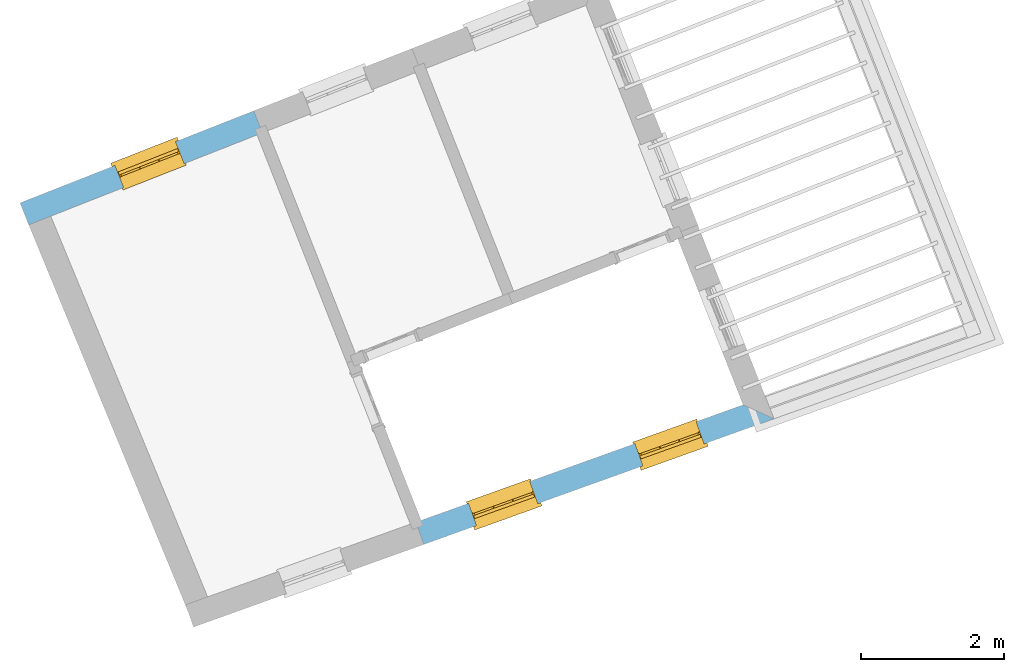
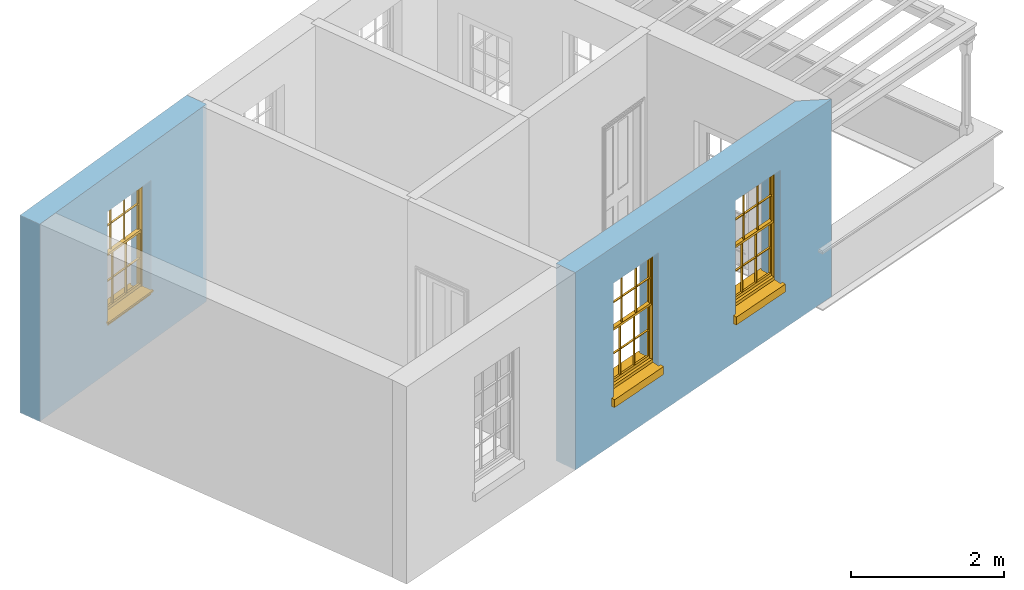
# One storey, part 3 of 8: 3 windows, 3 openings, plus 2 elements that do not belong to this part.
"""IFC2X3 building model written with IfcOpenShell, lengths in metres."""

from ifc_helpers import new_model, si_unit, frame, origin, place, context, subcontext, project, spatial, polyline, outline, extrude, faceted_brep, material, layer, layer_set, layer_usage, element, fill, save


model = new_model("IFC2X3")

# Units and contexts
model_context = context("Model", 3, world=origin())
body_context = subcontext(model_context, "Body", "Model", "MODEL_VIEW")
ifc_project = project(units=[si_unit("PLANEANGLEUNIT", "RADIAN"), si_unit("MASSUNIT", "GRAM", prefix="KILO"), si_unit("FORCEUNIT", "NEWTON", prefix="KILO"), si_unit("LENGTHUNIT", "METRE")], contexts=[model_context])

# Site, building, storey
site_placement = place(None, origin())
site = spatial("IfcSite", under=ifc_project, at=site_placement, CompositionType="ELEMENT")
building_placement = place(None, origin())
building = spatial("IfcBuilding", under=site, at=building_placement, Name="Building plot-4", CompositionType="ELEMENT")
storey_placement = place(None, frame((0.0, 0.0, 9.45)))
storey = spatial("IfcBuildingStorey", under=building, at=storey_placement, Name="Floor 2", CompositionType="ELEMENT", Elevation=9.45)

# Wall, openings, windows
ifc_material = material(Name="Masonry")
ifc_layer = layer(ifc_material, 0.33, ventilated=False)
ifc_layer_set = layer_set([ifc_layer], Name="My Wall")
ifc_layer_usage = layer_usage(ifc_layer_set, "AXIS2", "NEGATIVE", 0.08)
wall_1_placement = place(storey_placement, origin())
wall_1 = element("IfcWallStandardCase", 1, at=wall_1_placement, inside=storey, material=ifc_layer_usage, Name="exterior", context=body_context, shape_type="SweptSolid", body=[
    extrude(outline(polyline([(49.5927970052436, 46.539607653732), (49.70423854185, 46.2289940933087), (54.5866021542831, 47.9806822762042), (54.1548638616126, 48.176380175453), (49.5927970052436, 46.539607653732)])), origin(), (0.0, 0.0, 1.0), 3.15),
])
opening_1_placement = place(storey_placement, frame((0.0, 0.0, 0.75)))
opening_1 = element("IfcOpeningElement", 2, at=opening_1_placement, cuts=wall_1, Name="Opening", ObjectType="Opening", context=body_context, shape_type="SweptSolid", body=[
    extrude(outline(polyline([(50.4358969684534, 46.4914975693984), (51.2924373926509, 46.7988060491311), (51.1809958560445, 47.1094196095543), (50.3244554318471, 46.8021111298216), (50.4358969684534, 46.4914975693984)])), origin(), (0.0, 0.0, 1.0), 1.82),
])
opening_2_placement = place(storey_placement, frame((0.0, 0.0, 0.75)))
opening_2 = element("IfcOpeningElement", 3, at=opening_2_placement, cuts=wall_1, Name="Opening", ObjectType="Opening", context=body_context, shape_type="SweptSolid", body=[
    extrude(outline(polyline([(52.7557542458578, 47.3238130013103), (53.6122946700553, 47.631121481043), (53.5008531334489, 47.9417350414663), (52.6443127092515, 47.6344265617336), (52.7557542458578, 47.3238130013103)])), origin(), (0.0, 0.0, 1.0), 1.82),
])
window_1_placement = place(storey_placement, frame((50.3514715619335, 46.7268108727493, 0.75), z_axis=(0.0, 0.0, 1.0), x_axis=(0.856540424197469, 0.307308479732683, 0.0)))
window_1 = element("IfcWindow", 4, at=window_1_placement, inside=storey, Name="circulation outside window", OverallHeight=1.82, OverallWidth=0.91, context=body_context, shape_type="Brep", held_by="IfcProductRepresentation", body=[
    faceted_brep([(0.033125, -0.105, 0.975209), (0.01, -0.105, 0.975209), (0.033125, -0.105, 1.376042), (0.876875, -0.105, 0.975209), (0.876875, -0.105, 1.376042), (0.9, -0.105, 0.975209), (0.876875, -0.105, 1.386042), (0.876875, -0.105, 1.786875), (0.9, -0.105, 1.81), (0.033125, -0.105, 1.786875), (0.033125, -0.105, 1.386042), (0.01, -0.105, 1.81), (0.876875, -0.135, 1.376042), (0.876875, -0.135, 0.975209), (0.9, -0.135, 0.937083), (0.033125, -0.135, 1.786875), (0.01, -0.135, 1.81), (0.033125, -0.135, 1.386042), (0.01, -0.135, 0.937083), (0.033125, -0.135, 0.975209), (0.033125, -0.135, 1.376042), (0.876875, -0.135, 1.786875), (0.876875, -0.135, 1.386042), (0.9, -0.135, 1.81), (0.033125, -0.105, 0.937083), (0.01, -0.105, 0.937083), (0.033125, -0.105, 0.53625), (0.876875, -0.105, 0.937083), (0.876875, -0.105, 0.53625), (0.9, -0.105, 0.937083), (0.876875, -0.105, 0.52625), (0.876875, -0.105, 0.125417), (0.9, -0.105, 0.077167), (0.033125, -0.105, 0.125417), (0.033125, -0.105, 0.52625), (0.01, -0.105, 0.077167), (-0.0425, -0.25, 0.01), (-0.0425, -0.3, 0.001667), (0.0, -0.25, 0.01), (0.9525, -0.25, 0.01), (0.91, -0.25, 0.01), (0.9525, -0.3, 0.001667), (-0.02, 0.08, 0.077167), (0.0, 0.08, 0.077167), (-0.02, 0.11, 0.077167), (0.0, -0.06, 0.077167), (0.01, -0.06, 0.077167), (0.91, -0.06, 0.077167), (0.91, 0.08, 0.077167), (0.9, -0.06, 0.077167), (0.93, 0.08, 0.077167), (0.93, 0.11, 0.077167), (0.01, -0.075, 0.975209), (0.9, -0.075, 0.975209), (0.876875, -0.075, 0.125417), (0.876875, -0.075, 0.52625), (0.9, -0.075, 0.077167), (0.876875, -0.075, 0.53625), (0.876875, -0.075, 0.937083), (0.033125, -0.075, 0.125417), (0.01, -0.075, 0.077167), (0.033125, -0.075, 0.52625), (0.033125, -0.075, 0.937083), (0.033125, -0.075, 0.53625), (-0.02, 0.08, 0.052167), (-0.02, 0.11, 0.052167), (0.93, 0.11, 0.052167), (0.93, 0.08, 0.052167), (0.91, 0.08, 0.052167), (0.0, 0.08, 0.052167), (0.91, -0.15, 0.026667), (0.0, -0.15, 0.026667), (-0.0425, -0.3, -0.123333), (0.9525, -0.3, -0.123333), (-0.0425, -0.25, -0.123333), (0.9525, -0.25, -0.123333), (0.01, -0.06, 1.81), (0.9, -0.06, 1.81), (0.0, -0.06, 1.82), (0.91, -0.06, 1.82), (0.01, -0.15, 0.077167), (0.9, -0.15, 0.077167), (0.592292, -0.105, 0.125417), (0.592292, -0.075, 0.125417), (0.317708, -0.075, 0.125417), (0.317708, -0.105, 0.125417), (0.592292, -0.105, 0.53625), (0.317708, -0.105, 0.53625), (0.317708, -0.105, 0.52625), (0.592292, -0.105, 0.52625), (0.592292, -0.075, 0.53625), (0.317708, -0.075, 0.53625), (0.592292, -0.135, 1.386042), (0.592292, -0.105, 1.386042), (0.317708, -0.105, 1.386042), (0.317708, -0.135, 1.386042), (0.317708, -0.135, 1.376042), (0.592292, -0.135, 1.376042), (0.317708, -0.105, 1.376042), (0.592292, -0.105, 1.376042), (0.602292, -0.135, 1.376042), (0.592292, -0.135, 0.975209), (0.602292, -0.135, 0.975209), (0.602292, -0.105, 0.975209), (0.592292, -0.105, 0.975209), (0.602292, -0.105, 1.376042), (0.602292, -0.075, 0.53625), (0.602292, -0.105, 0.53625), (0.317708, -0.075, 0.52625), (0.307708, -0.075, 0.125417), (0.307708, -0.075, 0.52625), (0.602292, -0.075, 0.52625), (0.602292, -0.075, 0.125417), (0.592292, -0.075, 0.52625), (0.307708, -0.075, 0.53625), (0.317708, -0.075, 0.937083), (0.307708, -0.075, 0.937083), (0.602292, -0.075, 0.937083), (0.592292, -0.075, 0.937083), (0.307708, -0.105, 0.52625), (0.307708, -0.105, 0.125417), (0.307708, -0.105, 0.53625), (0.307708, -0.105, 0.937083), (0.592292, -0.105, 0.937083), (0.317708, -0.105, 0.937083), (0.602292, -0.105, 0.937083), (0.602292, -0.105, 0.52625), (0.602292, -0.105, 0.125417), (0.307708, -0.135, 1.386042), (0.307708, -0.135, 1.376042), (0.307708, -0.135, 0.975209), (0.317708, -0.135, 0.975209), (0.317708, -0.135, 1.786875), (0.307708, -0.135, 1.786875), (0.602292, -0.135, 1.786875), (0.592292, -0.135, 1.786875), (0.602292, -0.135, 1.386042), (0.602292, -0.105, 1.386042), (0.307708, -0.105, 1.386042), (0.307708, -0.105, 1.786875), (0.317708, -0.105, 1.786875), (0.592292, -0.105, 1.786875), (0.602292, -0.105, 1.786875), (0.307708, -0.105, 1.376042), (0.317708, -0.105, 0.975209), (0.307708, -0.105, 0.975209), (0.91, -0.15, 1.82), (0.9, -0.15, 1.81), (0.01, -0.15, 1.81), (0.0, -0.15, 1.82), (0.91, -0.25, 0.0), (0.0, -0.25, 0.0), (0.91, 0.08, 0.0), (0.0, 0.08, 0.0)], [[[0, 1, 2]], [[3, 4, 5]], [[6, 7, 8]], [[9, 10, 11]], [[12, 13, 14]], [[15, 16, 17]], [[18, 19, 20]], [[21, 22, 23]], [[24, 25, 26]], [[27, 28, 29]], [[30, 31, 32]], [[33, 34, 35]], [[14, 27, 29]], [[25, 24, 18]], [[36, 37, 38]], [[39, 40, 41]], [[42, 43, 44]], [[45, 46, 43]], [[47, 48, 49]], [[50, 51, 48]], [[1, 0, 52]], [[5, 53, 3]], [[54, 55, 56]], [[57, 58, 53]], [[59, 60, 61]], [[62, 63, 52]], [[48, 43, 46, 49]], [[51, 44, 43, 48]], [[64, 42, 44, 65]], [[65, 44, 51, 66]], [[66, 51, 50, 67]], [[65, 66, 68, 69]], [[60, 56, 49, 46]], [[70, 71, 38, 40]], [[37, 41, 40, 38]], [[37, 72, 73, 41]], [[74, 75, 73, 72]], [[8, 11, 76, 77]], [[76, 78, 79, 77]], [[32, 35, 80, 81]], [[81, 80, 71, 70]], [[82, 83, 84, 85]], [[86, 87, 88, 89]], [[86, 90, 91, 87]], [[92, 93, 94, 95]], [[92, 95, 96, 97]], [[96, 98, 99, 97]], [[100, 97, 101, 102]], [[103, 104, 99, 105]], [[97, 99, 104, 101]], [[102, 103, 105, 100]], [[28, 57, 106, 107]], [[108, 84, 109, 110]], [[111, 112, 83, 113]], [[114, 110, 61, 63]], [[90, 113, 108, 91]], [[115, 91, 114, 116]], [[117, 106, 90, 118]], [[111, 106, 57, 55]], [[119, 110, 109, 120]], [[34, 61, 110, 119]], [[89, 113, 83, 82]], [[88, 108, 113, 89]], [[85, 84, 108, 88]], [[121, 114, 63, 26]], [[122, 116, 114, 121]], [[123, 118, 90, 86]], [[87, 91, 115, 124]], [[107, 106, 117, 125]], [[126, 111, 55, 30]], [[127, 112, 111, 126]], [[126, 30, 28, 107]], [[88, 119, 120, 85]], [[126, 89, 82, 127]], [[125, 123, 86, 107]], [[121, 26, 34, 119]], [[124, 122, 121, 87]], [[128, 17, 20, 129]], [[96, 129, 130, 131]], [[132, 133, 128, 95]], [[134, 135, 92, 136]], [[100, 12, 22, 136]], [[137, 6, 4, 105]], [[94, 138, 139, 140]], [[137, 93, 141, 142]], [[99, 98, 94, 93]], [[143, 2, 10, 138]], [[144, 145, 143, 98]], [[129, 143, 145, 130]], [[20, 2, 143, 129]], [[131, 144, 98, 96]], [[128, 138, 10, 17]], [[133, 139, 138, 128]], [[135, 141, 93, 92]], [[95, 94, 140, 132]], [[22, 6, 137, 136]], [[136, 137, 142, 134]], [[100, 105, 4, 12]], [[107, 86, 89, 126]], [[106, 111, 113, 90]], [[91, 108, 110, 114]], [[87, 121, 119, 88]], [[97, 100, 136, 92]], [[129, 96, 95, 128]], [[98, 143, 138, 94]], [[105, 99, 93, 137]], [[131, 101, 104, 144]], [[124, 115, 118, 123]], [[132, 140, 141, 135]], [[120, 109, 59, 33]], [[15, 9, 139, 133]], [[134, 142, 7, 21]], [[31, 54, 112, 127]], [[36, 74, 72, 37]], [[39, 41, 73, 75]], [[18, 14, 101, 131]], [[23, 16, 132, 135]], [[83, 56, 60, 84]], [[52, 53, 118, 115]], [[53, 52, 144, 104]], [[11, 8, 141, 140]], [[14, 18, 124, 123]], [[2, 1, 11, 10]], [[8, 5, 4, 6]], [[57, 53, 56, 55]], [[60, 52, 63, 61]], [[26, 25, 35, 34]], [[32, 29, 28, 30]], [[14, 23, 22, 12]], [[18, 20, 17, 16]], [[19, 0, 2, 20]], [[17, 10, 9, 15]], [[12, 4, 3, 13]], [[21, 7, 6, 22]], [[27, 58, 57, 28]], [[30, 55, 54, 31]], [[33, 59, 61, 34]], [[26, 63, 62, 24]], [[5, 8, 77, 53]], [[76, 11, 1, 52]], [[46, 45, 78, 76]], [[49, 77, 79, 47]], [[70, 146, 147, 81]], [[71, 80, 148, 149]], [[19, 130, 145, 0]], [[102, 13, 3, 103]], [[116, 122, 24, 62]], [[29, 32, 81, 14]], [[80, 35, 25, 18]], [[60, 46, 76, 52]], [[77, 49, 56, 53]], [[23, 14, 81, 147]], [[16, 148, 80, 18]], [[35, 85, 120]], [[120, 33, 35]], [[127, 82, 32]], [[32, 31, 127]], [[32, 82, 85, 35]], [[102, 101, 14]], [[14, 13, 102]], [[18, 131, 130]], [[130, 19, 18]], [[134, 21, 23]], [[23, 135, 134]], [[16, 15, 133]], [[133, 132, 16]], [[11, 140, 139]], [[139, 9, 11]], [[142, 141, 8]], [[8, 7, 142]], [[23, 147, 148, 16]], [[146, 149, 148, 147]], [[52, 115, 116]], [[116, 62, 52]], [[118, 53, 117]], [[58, 117, 53]], [[27, 125, 117, 58]], [[56, 83, 112]], [[112, 54, 56]], [[109, 84, 60]], [[60, 59, 109]], [[125, 27, 14]], [[14, 123, 125]], [[122, 124, 18]], [[18, 24, 122]], [[145, 144, 52]], [[52, 0, 145]], [[103, 3, 53]], [[53, 104, 103]], [[79, 78, 149, 146]], [[78, 45, 71, 149]], [[146, 70, 47, 79]], [[150, 75, 74, 151]], [[68, 66, 67]], [[48, 68, 67, 50]], [[69, 64, 65]], [[42, 64, 69, 43]], [[69, 68, 152, 153]], [[70, 68, 48, 47]], [[150, 152, 68, 70]], [[43, 69, 71, 45]], [[69, 153, 151, 71]], [[152, 150, 151, 153]], [[38, 151, 74, 36]], [[71, 151, 38]], [[39, 75, 150, 40]], [[40, 150, 70]]]),
])
fill(opening_1, window_1)
window_2_placement = place(storey_placement, frame((52.6713288393379, 47.5591263046613, 0.75), z_axis=(0.0, 0.0, 1.0), x_axis=(0.856540424197469, 0.307308479732697, 0.0)))
window_2 = element("IfcWindow", 5, at=window_2_placement, inside=storey, Name="circulation outside window", OverallHeight=1.82, OverallWidth=0.91, context=body_context, shape_type="Brep", held_by="IfcProductRepresentation", body=[
    faceted_brep([(0.033125, -0.105, 0.975209), (0.01, -0.105, 0.975209), (0.033125, -0.105, 1.376042), (0.876875, -0.105, 0.975209), (0.876875, -0.105, 1.376042), (0.9, -0.105, 0.975209), (0.876875, -0.105, 1.386042), (0.876875, -0.105, 1.786875), (0.9, -0.105, 1.81), (0.033125, -0.105, 1.786875), (0.033125, -0.105, 1.386042), (0.01, -0.105, 1.81), (0.876875, -0.135, 1.376042), (0.876875, -0.135, 0.975209), (0.9, -0.135, 0.937083), (0.033125, -0.135, 1.786875), (0.01, -0.135, 1.81), (0.033125, -0.135, 1.386042), (0.01, -0.135, 0.937083), (0.033125, -0.135, 0.975209), (0.033125, -0.135, 1.376042), (0.876875, -0.135, 1.786875), (0.876875, -0.135, 1.386042), (0.9, -0.135, 1.81), (0.033125, -0.105, 0.937083), (0.01, -0.105, 0.937083), (0.033125, -0.105, 0.53625), (0.876875, -0.105, 0.937083), (0.876875, -0.105, 0.53625), (0.9, -0.105, 0.937083), (0.876875, -0.105, 0.52625), (0.876875, -0.105, 0.125417), (0.9, -0.105, 0.077167), (0.033125, -0.105, 0.125417), (0.033125, -0.105, 0.52625), (0.01, -0.105, 0.077167), (-0.0425, -0.25, 0.01), (-0.0425, -0.3, 0.001667), (0.0, -0.25, 0.01), (0.9525, -0.25, 0.01), (0.91, -0.25, 0.01), (0.9525, -0.3, 0.001667), (-0.02, 0.08, 0.077167), (0.0, 0.08, 0.077167), (-0.02, 0.11, 0.077167), (0.0, -0.06, 0.077167), (0.01, -0.06, 0.077167), (0.91, -0.06, 0.077167), (0.91, 0.08, 0.077167), (0.9, -0.06, 0.077167), (0.93, 0.08, 0.077167), (0.93, 0.11, 0.077167), (0.01, -0.075, 0.975209), (0.9, -0.075, 0.975209), (0.876875, -0.075, 0.125417), (0.876875, -0.075, 0.52625), (0.9, -0.075, 0.077167), (0.876875, -0.075, 0.53625), (0.876875, -0.075, 0.937083), (0.033125, -0.075, 0.125417), (0.01, -0.075, 0.077167), (0.033125, -0.075, 0.52625), (0.033125, -0.075, 0.937083), (0.033125, -0.075, 0.53625), (-0.02, 0.08, 0.052167), (-0.02, 0.11, 0.052167), (0.93, 0.11, 0.052167), (0.93, 0.08, 0.052167), (0.91, 0.08, 0.052167), (0.0, 0.08, 0.052167), (0.91, -0.15, 0.026667), (0.0, -0.15, 0.026667), (-0.0425, -0.3, -0.123333), (0.9525, -0.3, -0.123333), (-0.0425, -0.25, -0.123333), (0.9525, -0.25, -0.123333), (0.01, -0.06, 1.81), (0.9, -0.06, 1.81), (0.0, -0.06, 1.82), (0.91, -0.06, 1.82), (0.01, -0.15, 0.077167), (0.9, -0.15, 0.077167), (0.592292, -0.105, 0.125417), (0.592292, -0.075, 0.125417), (0.317708, -0.075, 0.125417), (0.317708, -0.105, 0.125417), (0.592292, -0.105, 0.53625), (0.317708, -0.105, 0.53625), (0.317708, -0.105, 0.52625), (0.592292, -0.105, 0.52625), (0.592292, -0.075, 0.53625), (0.317708, -0.075, 0.53625), (0.592292, -0.135, 1.386042), (0.592292, -0.105, 1.386042), (0.317708, -0.105, 1.386042), (0.317708, -0.135, 1.386042), (0.317708, -0.135, 1.376042), (0.592292, -0.135, 1.376042), (0.317708, -0.105, 1.376042), (0.592292, -0.105, 1.376042), (0.602292, -0.135, 1.376042), (0.592292, -0.135, 0.975209), (0.602292, -0.135, 0.975209), (0.602292, -0.105, 0.975209), (0.592292, -0.105, 0.975209), (0.602292, -0.105, 1.376042), (0.602292, -0.075, 0.53625), (0.602292, -0.105, 0.53625), (0.317708, -0.075, 0.52625), (0.307708, -0.075, 0.125417), (0.307708, -0.075, 0.52625), (0.602292, -0.075, 0.52625), (0.602292, -0.075, 0.125417), (0.592292, -0.075, 0.52625), (0.307708, -0.075, 0.53625), (0.317708, -0.075, 0.937083), (0.307708, -0.075, 0.937083), (0.602292, -0.075, 0.937083), (0.592292, -0.075, 0.937083), (0.307708, -0.105, 0.52625), (0.307708, -0.105, 0.125417), (0.307708, -0.105, 0.53625), (0.307708, -0.105, 0.937083), (0.592292, -0.105, 0.937083), (0.317708, -0.105, 0.937083), (0.602292, -0.105, 0.937083), (0.602292, -0.105, 0.52625), (0.602292, -0.105, 0.125417), (0.307708, -0.135, 1.386042), (0.307708, -0.135, 1.376042), (0.307708, -0.135, 0.975209), (0.317708, -0.135, 0.975209), (0.317708, -0.135, 1.786875), (0.307708, -0.135, 1.786875), (0.602292, -0.135, 1.786875), (0.592292, -0.135, 1.786875), (0.602292, -0.135, 1.386042), (0.602292, -0.105, 1.386042), (0.307708, -0.105, 1.386042), (0.307708, -0.105, 1.786875), (0.317708, -0.105, 1.786875), (0.592292, -0.105, 1.786875), (0.602292, -0.105, 1.786875), (0.307708, -0.105, 1.376042), (0.317708, -0.105, 0.975209), (0.307708, -0.105, 0.975209), (0.91, -0.15, 1.82), (0.9, -0.15, 1.81), (0.01, -0.15, 1.81), (0.0, -0.15, 1.82), (0.91, -0.25, 0.0), (0.0, -0.25, 0.0), (0.91, 0.08, 0.0), (0.0, 0.08, 0.0)], [[[0, 1, 2]], [[3, 4, 5]], [[6, 7, 8]], [[9, 10, 11]], [[12, 13, 14]], [[15, 16, 17]], [[18, 19, 20]], [[21, 22, 23]], [[24, 25, 26]], [[27, 28, 29]], [[30, 31, 32]], [[33, 34, 35]], [[14, 27, 29]], [[25, 24, 18]], [[36, 37, 38]], [[39, 40, 41]], [[42, 43, 44]], [[45, 46, 43]], [[47, 48, 49]], [[50, 51, 48]], [[1, 0, 52]], [[5, 53, 3]], [[54, 55, 56]], [[57, 58, 53]], [[59, 60, 61]], [[62, 63, 52]], [[48, 43, 46, 49]], [[51, 44, 43, 48]], [[64, 42, 44, 65]], [[65, 44, 51, 66]], [[66, 51, 50, 67]], [[65, 66, 68, 69]], [[60, 56, 49, 46]], [[70, 71, 38, 40]], [[37, 41, 40, 38]], [[37, 72, 73, 41]], [[74, 75, 73, 72]], [[8, 11, 76, 77]], [[76, 78, 79, 77]], [[32, 35, 80, 81]], [[81, 80, 71, 70]], [[82, 83, 84, 85]], [[86, 87, 88, 89]], [[86, 90, 91, 87]], [[92, 93, 94, 95]], [[92, 95, 96, 97]], [[96, 98, 99, 97]], [[100, 97, 101, 102]], [[103, 104, 99, 105]], [[97, 99, 104, 101]], [[102, 103, 105, 100]], [[28, 57, 106, 107]], [[108, 84, 109, 110]], [[111, 112, 83, 113]], [[114, 110, 61, 63]], [[90, 113, 108, 91]], [[115, 91, 114, 116]], [[117, 106, 90, 118]], [[111, 106, 57, 55]], [[119, 110, 109, 120]], [[34, 61, 110, 119]], [[89, 113, 83, 82]], [[88, 108, 113, 89]], [[85, 84, 108, 88]], [[121, 114, 63, 26]], [[122, 116, 114, 121]], [[123, 118, 90, 86]], [[87, 91, 115, 124]], [[107, 106, 117, 125]], [[126, 111, 55, 30]], [[127, 112, 111, 126]], [[126, 30, 28, 107]], [[88, 119, 120, 85]], [[126, 89, 82, 127]], [[125, 123, 86, 107]], [[121, 26, 34, 119]], [[124, 122, 121, 87]], [[128, 17, 20, 129]], [[96, 129, 130, 131]], [[132, 133, 128, 95]], [[134, 135, 92, 136]], [[100, 12, 22, 136]], [[137, 6, 4, 105]], [[94, 138, 139, 140]], [[137, 93, 141, 142]], [[99, 98, 94, 93]], [[143, 2, 10, 138]], [[144, 145, 143, 98]], [[129, 143, 145, 130]], [[20, 2, 143, 129]], [[131, 144, 98, 96]], [[128, 138, 10, 17]], [[133, 139, 138, 128]], [[135, 141, 93, 92]], [[95, 94, 140, 132]], [[22, 6, 137, 136]], [[136, 137, 142, 134]], [[100, 105, 4, 12]], [[107, 86, 89, 126]], [[106, 111, 113, 90]], [[91, 108, 110, 114]], [[87, 121, 119, 88]], [[97, 100, 136, 92]], [[129, 96, 95, 128]], [[98, 143, 138, 94]], [[105, 99, 93, 137]], [[131, 101, 104, 144]], [[124, 115, 118, 123]], [[132, 140, 141, 135]], [[120, 109, 59, 33]], [[15, 9, 139, 133]], [[134, 142, 7, 21]], [[31, 54, 112, 127]], [[36, 74, 72, 37]], [[39, 41, 73, 75]], [[18, 14, 101, 131]], [[23, 16, 132, 135]], [[83, 56, 60, 84]], [[52, 53, 118, 115]], [[53, 52, 144, 104]], [[11, 8, 141, 140]], [[14, 18, 124, 123]], [[2, 1, 11, 10]], [[8, 5, 4, 6]], [[57, 53, 56, 55]], [[60, 52, 63, 61]], [[26, 25, 35, 34]], [[32, 29, 28, 30]], [[14, 23, 22, 12]], [[18, 20, 17, 16]], [[19, 0, 2, 20]], [[17, 10, 9, 15]], [[12, 4, 3, 13]], [[21, 7, 6, 22]], [[27, 58, 57, 28]], [[30, 55, 54, 31]], [[33, 59, 61, 34]], [[26, 63, 62, 24]], [[5, 8, 77, 53]], [[76, 11, 1, 52]], [[46, 45, 78, 76]], [[49, 77, 79, 47]], [[70, 146, 147, 81]], [[71, 80, 148, 149]], [[19, 130, 145, 0]], [[102, 13, 3, 103]], [[116, 122, 24, 62]], [[29, 32, 81, 14]], [[80, 35, 25, 18]], [[60, 46, 76, 52]], [[77, 49, 56, 53]], [[23, 14, 81, 147]], [[16, 148, 80, 18]], [[35, 85, 120]], [[120, 33, 35]], [[127, 82, 32]], [[32, 31, 127]], [[32, 82, 85, 35]], [[102, 101, 14]], [[14, 13, 102]], [[18, 131, 130]], [[130, 19, 18]], [[134, 21, 23]], [[23, 135, 134]], [[16, 15, 133]], [[133, 132, 16]], [[11, 140, 139]], [[139, 9, 11]], [[142, 141, 8]], [[8, 7, 142]], [[23, 147, 148, 16]], [[146, 149, 148, 147]], [[52, 115, 116]], [[116, 62, 52]], [[118, 53, 117]], [[58, 117, 53]], [[27, 125, 117, 58]], [[56, 83, 112]], [[112, 54, 56]], [[109, 84, 60]], [[60, 59, 109]], [[125, 27, 14]], [[14, 123, 125]], [[122, 124, 18]], [[18, 24, 122]], [[145, 144, 52]], [[52, 0, 145]], [[103, 3, 53]], [[53, 104, 103]], [[79, 78, 149, 146]], [[78, 45, 71, 149]], [[146, 70, 47, 79]], [[150, 75, 74, 151]], [[68, 66, 67]], [[48, 68, 67, 50]], [[69, 64, 65]], [[42, 64, 69, 43]], [[69, 68, 152, 153]], [[70, 68, 48, 47]], [[150, 152, 68, 70]], [[43, 69, 71, 45]], [[69, 153, 151, 71]], [[152, 150, 151, 153]], [[38, 151, 74, 36]], [[71, 151, 38]], [[39, 75, 150, 40]], [[40, 150, 70]]]),
])
fill(opening_2, window_2)

# Wall, opening, window
wall_2_placement = place(storey_placement, origin())
wall_2 = element("IfcWallStandardCase", 6, at=wall_2_placement, inside=storey, material=ifc_layer_usage, Name="exterior", context=body_context, shape_type="SweptSolid", body=[
    extrude(outline(polyline([(47.4524085148317, 51.9678474183833), (47.3314871355126, 52.2748946786277), (44.0729122767796, 50.9916024381462), (44.1938336560988, 50.6845551779018), (47.4524085148317, 51.9678474183833)])), origin(), (0.0, 0.0, 1.0), 3.15),
])
opening_3_placement = place(storey_placement, frame((0.0, 0.0, 0.75)))
opening_3 = element("IfcOpeningElement", 7, at=opening_3_placement, cuts=wall_2, Name="Opening", ObjectType="Opening", context=body_context, shape_type="SweptSolid", body=[
    extrude(outline(polyline([(46.2418585271816, 51.8457770432509), (45.3951524459018, 51.5123271790678), (45.5160738252209, 51.2052799188234), (46.3627799065008, 51.5387297830065), (46.2418585271816, 51.8457770432509)])), origin(), (0.0, 0.0, 1.0), 1.82),
])
window_3_placement = place(storey_placement, frame((46.3334656327264, 51.6131654824597, 0.75), z_axis=(0.0, 0.0, 1.0), x_axis=(-0.846706081279848, -0.333449864183088, 0.0)))
window_3 = element("IfcWindow", 8, at=window_3_placement, inside=storey, Name="bedroom outside window", OverallHeight=1.82, OverallWidth=0.91, context=body_context, shape_type="Brep", held_by="IfcProductRepresentation", body=[
    faceted_brep([(0.033125, -0.105, 0.975209), (0.01, -0.105, 0.975209), (0.033125, -0.105, 1.376042), (0.876875, -0.105, 0.975209), (0.876875, -0.105, 1.376042), (0.9, -0.105, 0.975209), (0.876875, -0.105, 1.386042), (0.876875, -0.105, 1.786875), (0.9, -0.105, 1.81), (0.033125, -0.105, 1.786875), (0.033125, -0.105, 1.386042), (0.01, -0.105, 1.81), (0.876875, -0.135, 1.376042), (0.876875, -0.135, 0.975209), (0.9, -0.135, 0.937083), (0.033125, -0.135, 1.786875), (0.01, -0.135, 1.81), (0.033125, -0.135, 1.386042), (0.01, -0.135, 0.937083), (0.033125, -0.135, 0.975209), (0.033125, -0.135, 1.376042), (0.876875, -0.135, 1.786875), (0.876875, -0.135, 1.386042), (0.9, -0.135, 1.81), (0.033125, -0.105, 0.937083), (0.01, -0.105, 0.937083), (0.033125, -0.105, 0.53625), (0.876875, -0.105, 0.937083), (0.876875, -0.105, 0.53625), (0.9, -0.105, 0.937083), (0.876875, -0.105, 0.52625), (0.876875, -0.105, 0.125417), (0.9, -0.105, 0.077167), (0.033125, -0.105, 0.125417), (0.033125, -0.105, 0.52625), (0.01, -0.105, 0.077167), (-0.0425, -0.25, 0.01), (-0.0425, -0.3, 0.001667), (0.0, -0.25, 0.01), (0.9525, -0.25, 0.01), (0.91, -0.25, 0.01), (0.9525, -0.3, 0.001667), (-0.02, 0.08, 0.077167), (0.0, 0.08, 0.077167), (-0.02, 0.11, 0.077167), (0.0, -0.06, 0.077167), (0.01, -0.06, 0.077167), (0.91, -0.06, 0.077167), (0.91, 0.08, 0.077167), (0.9, -0.06, 0.077167), (0.93, 0.08, 0.077167), (0.93, 0.11, 0.077167), (0.01, -0.075, 0.975209), (0.9, -0.075, 0.975209), (0.876875, -0.075, 0.125417), (0.876875, -0.075, 0.52625), (0.9, -0.075, 0.077167), (0.876875, -0.075, 0.53625), (0.876875, -0.075, 0.937083), (0.033125, -0.075, 0.125417), (0.01, -0.075, 0.077167), (0.033125, -0.075, 0.52625), (0.033125, -0.075, 0.937083), (0.033125, -0.075, 0.53625), (-0.02, 0.08, 0.052167), (-0.02, 0.11, 0.052167), (0.93, 0.11, 0.052167), (0.93, 0.08, 0.052167), (0.91, 0.08, 0.052167), (0.0, 0.08, 0.052167), (0.91, -0.15, 0.026667), (0.0, -0.15, 0.026667), (-0.0425, -0.3, -0.123333), (0.9525, -0.3, -0.123333), (-0.0425, -0.25, -0.123333), (0.9525, -0.25, -0.123333), (0.01, -0.06, 1.81), (0.9, -0.06, 1.81), (0.0, -0.06, 1.82), (0.91, -0.06, 1.82), (0.01, -0.15, 0.077167), (0.9, -0.15, 0.077167), (0.592292, -0.105, 0.125417), (0.592292, -0.075, 0.125417), (0.317708, -0.075, 0.125417), (0.317708, -0.105, 0.125417), (0.592292, -0.105, 0.53625), (0.317708, -0.105, 0.53625), (0.317708, -0.105, 0.52625), (0.592292, -0.105, 0.52625), (0.592292, -0.075, 0.53625), (0.317708, -0.075, 0.53625), (0.592292, -0.135, 1.386042), (0.592292, -0.105, 1.386042), (0.317708, -0.105, 1.386042), (0.317708, -0.135, 1.386042), (0.317708, -0.135, 1.376042), (0.592292, -0.135, 1.376042), (0.317708, -0.105, 1.376042), (0.592292, -0.105, 1.376042), (0.602292, -0.135, 1.376042), (0.592292, -0.135, 0.975209), (0.602292, -0.135, 0.975209), (0.602292, -0.105, 0.975209), (0.592292, -0.105, 0.975209), (0.602292, -0.105, 1.376042), (0.602292, -0.075, 0.53625), (0.602292, -0.105, 0.53625), (0.317708, -0.075, 0.52625), (0.307708, -0.075, 0.125417), (0.307708, -0.075, 0.52625), (0.602292, -0.075, 0.52625), (0.602292, -0.075, 0.125417), (0.592292, -0.075, 0.52625), (0.307708, -0.075, 0.53625), (0.317708, -0.075, 0.937083), (0.307708, -0.075, 0.937083), (0.602292, -0.075, 0.937083), (0.592292, -0.075, 0.937083), (0.307708, -0.105, 0.52625), (0.307708, -0.105, 0.125417), (0.307708, -0.105, 0.53625), (0.307708, -0.105, 0.937083), (0.592292, -0.105, 0.937083), (0.317708, -0.105, 0.937083), (0.602292, -0.105, 0.937083), (0.602292, -0.105, 0.52625), (0.602292, -0.105, 0.125417), (0.307708, -0.135, 1.386042), (0.307708, -0.135, 1.376042), (0.307708, -0.135, 0.975209), (0.317708, -0.135, 0.975209), (0.317708, -0.135, 1.786875), (0.307708, -0.135, 1.786875), (0.602292, -0.135, 1.786875), (0.592292, -0.135, 1.786875), (0.602292, -0.135, 1.386042), (0.602292, -0.105, 1.386042), (0.307708, -0.105, 1.386042), (0.307708, -0.105, 1.786875), (0.317708, -0.105, 1.786875), (0.592292, -0.105, 1.786875), (0.602292, -0.105, 1.786875), (0.307708, -0.105, 1.376042), (0.317708, -0.105, 0.975209), (0.307708, -0.105, 0.975209), (0.91, -0.15, 1.82), (0.9, -0.15, 1.81), (0.01, -0.15, 1.81), (0.0, -0.15, 1.82), (0.91, -0.25, 0.0), (0.0, -0.25, 0.0), (0.91, 0.08, 0.0), (0.0, 0.08, 0.0)], [[[0, 1, 2]], [[3, 4, 5]], [[6, 7, 8]], [[9, 10, 11]], [[12, 13, 14]], [[15, 16, 17]], [[18, 19, 20]], [[21, 22, 23]], [[24, 25, 26]], [[27, 28, 29]], [[30, 31, 32]], [[33, 34, 35]], [[14, 27, 29]], [[25, 24, 18]], [[36, 37, 38]], [[39, 40, 41]], [[42, 43, 44]], [[45, 46, 43]], [[47, 48, 49]], [[50, 51, 48]], [[1, 0, 52]], [[5, 53, 3]], [[54, 55, 56]], [[57, 58, 53]], [[59, 60, 61]], [[62, 63, 52]], [[48, 43, 46, 49]], [[51, 44, 43, 48]], [[64, 42, 44, 65]], [[65, 44, 51, 66]], [[66, 51, 50, 67]], [[65, 66, 68, 69]], [[60, 56, 49, 46]], [[70, 71, 38, 40]], [[37, 41, 40, 38]], [[37, 72, 73, 41]], [[74, 75, 73, 72]], [[8, 11, 76, 77]], [[76, 78, 79, 77]], [[32, 35, 80, 81]], [[81, 80, 71, 70]], [[82, 83, 84, 85]], [[86, 87, 88, 89]], [[86, 90, 91, 87]], [[92, 93, 94, 95]], [[92, 95, 96, 97]], [[96, 98, 99, 97]], [[100, 97, 101, 102]], [[103, 104, 99, 105]], [[97, 99, 104, 101]], [[102, 103, 105, 100]], [[28, 57, 106, 107]], [[108, 84, 109, 110]], [[111, 112, 83, 113]], [[114, 110, 61, 63]], [[90, 113, 108, 91]], [[115, 91, 114, 116]], [[117, 106, 90, 118]], [[111, 106, 57, 55]], [[119, 110, 109, 120]], [[34, 61, 110, 119]], [[89, 113, 83, 82]], [[88, 108, 113, 89]], [[85, 84, 108, 88]], [[121, 114, 63, 26]], [[122, 116, 114, 121]], [[123, 118, 90, 86]], [[87, 91, 115, 124]], [[107, 106, 117, 125]], [[126, 111, 55, 30]], [[127, 112, 111, 126]], [[126, 30, 28, 107]], [[88, 119, 120, 85]], [[126, 89, 82, 127]], [[125, 123, 86, 107]], [[121, 26, 34, 119]], [[124, 122, 121, 87]], [[128, 17, 20, 129]], [[96, 129, 130, 131]], [[132, 133, 128, 95]], [[134, 135, 92, 136]], [[100, 12, 22, 136]], [[137, 6, 4, 105]], [[94, 138, 139, 140]], [[137, 93, 141, 142]], [[99, 98, 94, 93]], [[143, 2, 10, 138]], [[144, 145, 143, 98]], [[129, 143, 145, 130]], [[20, 2, 143, 129]], [[131, 144, 98, 96]], [[128, 138, 10, 17]], [[133, 139, 138, 128]], [[135, 141, 93, 92]], [[95, 94, 140, 132]], [[22, 6, 137, 136]], [[136, 137, 142, 134]], [[100, 105, 4, 12]], [[107, 86, 89, 126]], [[106, 111, 113, 90]], [[91, 108, 110, 114]], [[87, 121, 119, 88]], [[97, 100, 136, 92]], [[129, 96, 95, 128]], [[98, 143, 138, 94]], [[105, 99, 93, 137]], [[131, 101, 104, 144]], [[124, 115, 118, 123]], [[132, 140, 141, 135]], [[120, 109, 59, 33]], [[15, 9, 139, 133]], [[134, 142, 7, 21]], [[31, 54, 112, 127]], [[36, 74, 72, 37]], [[39, 41, 73, 75]], [[18, 14, 101, 131]], [[23, 16, 132, 135]], [[83, 56, 60, 84]], [[52, 53, 118, 115]], [[53, 52, 144, 104]], [[11, 8, 141, 140]], [[14, 18, 124, 123]], [[2, 1, 11, 10]], [[8, 5, 4, 6]], [[57, 53, 56, 55]], [[60, 52, 63, 61]], [[26, 25, 35, 34]], [[32, 29, 28, 30]], [[14, 23, 22, 12]], [[18, 20, 17, 16]], [[19, 0, 2, 20]], [[17, 10, 9, 15]], [[12, 4, 3, 13]], [[21, 7, 6, 22]], [[27, 58, 57, 28]], [[30, 55, 54, 31]], [[33, 59, 61, 34]], [[26, 63, 62, 24]], [[5, 8, 77, 53]], [[76, 11, 1, 52]], [[46, 45, 78, 76]], [[49, 77, 79, 47]], [[70, 146, 147, 81]], [[71, 80, 148, 149]], [[19, 130, 145, 0]], [[102, 13, 3, 103]], [[116, 122, 24, 62]], [[29, 32, 81, 14]], [[80, 35, 25, 18]], [[60, 46, 76, 52]], [[77, 49, 56, 53]], [[23, 14, 81, 147]], [[16, 148, 80, 18]], [[35, 85, 120]], [[120, 33, 35]], [[127, 82, 32]], [[32, 31, 127]], [[32, 82, 85, 35]], [[102, 101, 14]], [[14, 13, 102]], [[18, 131, 130]], [[130, 19, 18]], [[134, 21, 23]], [[23, 135, 134]], [[16, 15, 133]], [[133, 132, 16]], [[11, 140, 139]], [[139, 9, 11]], [[142, 141, 8]], [[8, 7, 142]], [[23, 147, 148, 16]], [[146, 149, 148, 147]], [[52, 115, 116]], [[116, 62, 52]], [[118, 53, 117]], [[58, 117, 53]], [[27, 125, 117, 58]], [[56, 83, 112]], [[112, 54, 56]], [[109, 84, 60]], [[60, 59, 109]], [[125, 27, 14]], [[14, 123, 125]], [[122, 124, 18]], [[18, 24, 122]], [[145, 144, 52]], [[52, 0, 145]], [[103, 3, 53]], [[53, 104, 103]], [[79, 78, 149, 146]], [[78, 45, 71, 149]], [[146, 70, 47, 79]], [[150, 75, 74, 151]], [[68, 66, 67]], [[48, 68, 67, 50]], [[69, 64, 65]], [[42, 64, 69, 43]], [[69, 68, 152, 153]], [[70, 68, 48, 47]], [[150, 152, 68, 70]], [[43, 69, 71, 45]], [[69, 153, 151, 71]], [[152, 150, 151, 153]], [[38, 151, 74, 36]], [[71, 151, 38]], [[39, 75, 150, 40]], [[40, 150, 70]]]),
])
fill(opening_3, window_3)

save(model, "model.ifc")
